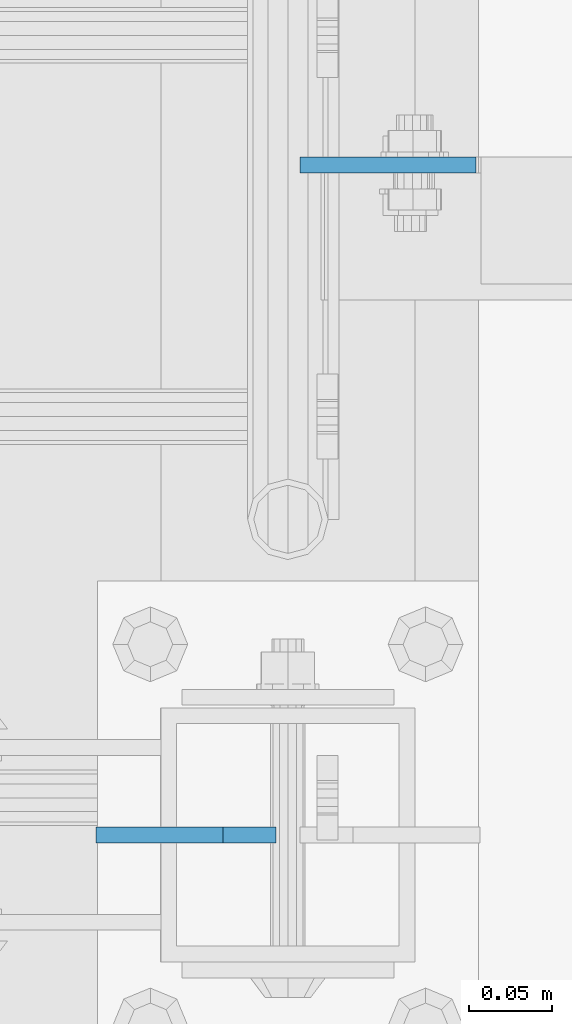
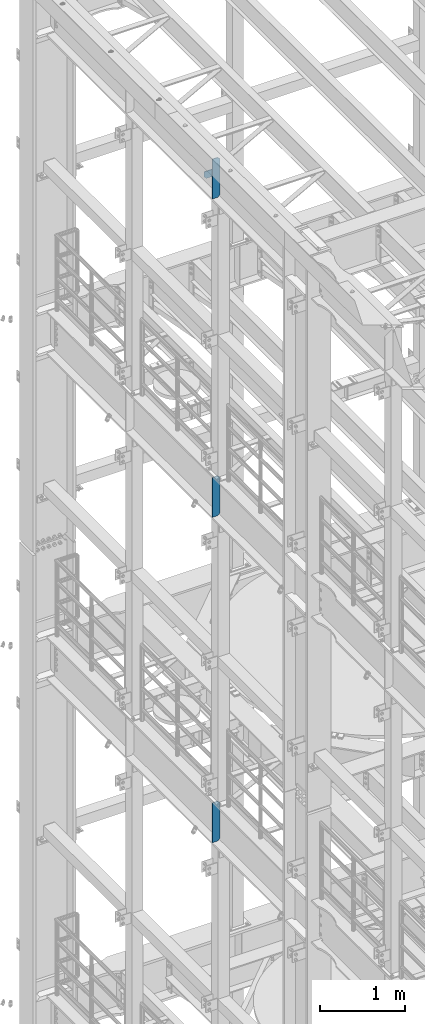
# One storey, part 1711 of 1876: 4 plates, 3 elements without a shape of their own.
"""IFC2X3 building model written with IfcOpenShell, lengths in millimetres."""

from ifc_helpers import new_model, si_unit, frame, origin_with_axes, place, context, subcontext, project, spatial, faceted_brep, material, type_object, element, aggregate, save


model = new_model("IFC2X3")

# Units and contexts
model_context = context("Model", 3, precision=1e-05, world=origin_with_axes())
body_context = subcontext(model_context, "Body", "Model", "MODEL_VIEW")
ifc_project = project(units=[si_unit("LENGTHUNIT", "METRE", prefix="MILLI"), si_unit("AREAUNIT", "SQUARE_METRE"), si_unit("VOLUMEUNIT", "CUBIC_METRE"), si_unit("MASSUNIT", "GRAM", prefix="KILO"), si_unit("TIMEUNIT", "SECOND"), si_unit("PLANEANGLEUNIT", "RADIAN"), si_unit("SOLIDANGLEUNIT", "STERADIAN"), si_unit("THERMODYNAMICTEMPERATUREUNIT", "DEGREE_CELSIUS"), si_unit("LUMINOUSINTENSITYUNIT", "LUMEN")], contexts=[model_context])

# Site, building, storey
site_placement = place(None, origin_with_axes())
site = spatial("IfcSite", under=ifc_project, at=site_placement, CompositionType="ELEMENT")
building_placement = place(site_placement, origin_with_axes())
building = spatial("IfcBuilding", under=site, at=building_placement, Name="Undefined", CompositionType="ELEMENT")
storey_placement = place(building_placement, origin_with_axes())
storey = spatial("IfcBuildingStorey", under=building, at=storey_placement, Name="Undefined", CompositionType="ELEMENT", Elevation=0.0)

# Assembly, plates
assembly_1_placement = place(storey_placement, origin_with_axes())
assembly_1 = element("IfcElementAssembly", 1, at=assembly_1_placement, inside=storey, Name="BEAM", AssemblyPlace="NOTDEFINED", PredefinedType="RIGID_FRAME")
ifc_material = material(Name="STEEL/A36")
plate_type_1 = type_object("IfcPlateType", PredefinedType="NOTDEFINED")
plate_1_placement = place(assembly_1_placement, frame((7.14374999999999, 10053.6375, 21958.3), z_axis=(0.0, 0.0, 1.0), x_axis=(1.0, 0.0, 0.0)))
plate_1 = element("IfcPlate", 2, at=plate_1_placement, type_object=plate_type_1, material=ifc_material, Name="PLATE", context=body_context, shape_type="Brep", body=[
    faceted_brep([(-9.76996261670138e-14, -4.76250000000073, 31.75), (-3.4106151360902e-06, -4.76249999999982, 104.420860290527), (-3.4106151360902e-06, 4.76249999999982, 104.420860290527), (-9.76996261670138e-14, 4.76250000000073, 31.75), (105.552177429199, -4.76249999999982, 104.420860290527), (105.552177429199, 4.76249999999982, 104.420860290527), (105.552177429199, -4.76249999999982, 0.0), (105.552177429199, 4.76249999999982, 0.0), (31.75, -4.76250000000073, 0.0), (31.75, 4.76250000000073, 0.0)], [[[0, 1, 2, 3]], [[1, 4, 5, 2]], [[4, 6, 7, 5]], [[6, 8, 9, 7]], [[8, 0, 3, 9]], [[5, 7, 9, 3, 2]], [[8, 6, 4, 1, 0]]]),
])
plate_type_2 = type_object("IfcPlateType", PredefinedType="NOTDEFINED")
plate_2_placement = place(assembly_1_placement, frame((-7.14374915193636, 9651.9999999841, 21958.3), z_axis=(0.0, 0.0, 1.0), x_axis=(-1.0, 0.0, 0.0)))
plate_2 = element("IfcPlate", 3, at=plate_2_placement, type_object=plate_type_2, material=ifc_material, Name="PLATE", context=body_context, shape_type="Brep", body=[
    faceted_brep([(-9.76996261670138e-14, -4.76250000000073, 31.75), (0.0, -4.76249999999982, 539.75), (0.0, 4.76249999999982, 539.75), (-9.76996261670138e-14, 4.76250000000073, 31.75), (31.75, -4.76249999999982, 571.5), (31.75, 4.76249999999982, 571.5), (107.949996948242, -4.76249999999982, 571.5), (107.949996948242, 4.76249999999982, 571.5), (107.950006484985, -4.76250000000073, 0.0), (107.950006484985, 4.76250000000073, 0.0), (31.75, -4.76250000000073, 0.0), (31.75, 4.76250000000073, 0.0)], [[[0, 1, 2, 3]], [[1, 4, 5, 2]], [[4, 6, 7, 5]], [[6, 8, 9, 7]], [[8, 10, 11, 9]], [[10, 0, 3, 11]], [[5, 7, 9, 11, 3, 2]], [[10, 8, 6, 4, 1, 0]]]),
])
aggregate(assembly_1, [plate_1, plate_2])

# Assembly, plate
assembly_2_placement = place(storey_placement, origin_with_axes())
assembly_2 = element("IfcElementAssembly", 4, at=assembly_2_placement, inside=storey, Name="BEAM", AssemblyPlace="NOTDEFINED", PredefinedType="RIGID_FRAME")
plate_3_placement = place(assembly_2_placement, frame((-7.14374915193636, 9651.9999999841, 17386.3), z_axis=(0.0, 0.0, 1.0), x_axis=(-1.0, 0.0, 0.0)))
plate_3 = element("IfcPlate", 5, at=plate_3_placement, type_object=plate_type_2, material=ifc_material, Name="PLATE", context=body_context, shape_type="Brep", body=[
    faceted_brep([(-9.76996261670138e-14, -4.76250000000073, 31.75), (0.0, -4.76249999999982, 539.75), (0.0, 4.76249999999982, 539.75), (-9.76996261670138e-14, 4.76250000000073, 31.75), (31.75, -4.76249999999982, 571.5), (31.75, 4.76249999999982, 571.5), (107.949996948242, -4.76249999999982, 571.5), (107.949996948242, 4.76249999999982, 571.5), (107.950006484985, -4.76250000000073, 0.0), (107.950006484985, 4.76250000000073, 0.0), (31.75, -4.76250000000073, 0.0), (31.75, 4.76250000000073, 0.0)], [[[0, 1, 2, 3]], [[1, 4, 5, 2]], [[4, 6, 7, 5]], [[6, 8, 9, 7]], [[8, 10, 11, 9]], [[10, 0, 3, 11]], [[5, 7, 9, 11, 3, 2]], [[10, 8, 6, 4, 1, 0]]]),
])
aggregate(assembly_2, [plate_3])

assembly_3_placement = place(storey_placement, origin_with_axes())
assembly_3 = element("IfcElementAssembly", 6, at=assembly_3_placement, inside=storey, Name="BEAM", AssemblyPlace="NOTDEFINED", PredefinedType="RIGID_FRAME")
plate_4_placement = place(assembly_3_placement, frame((-7.14374915193636, 9651.9999999841, 12712.7), z_axis=(0.0, 0.0, 1.0), x_axis=(-1.0, 0.0, 0.0)))
plate_4 = element("IfcPlate", 7, at=plate_4_placement, type_object=plate_type_2, material=ifc_material, Name="PLATE", context=body_context, shape_type="Brep", body=[
    faceted_brep([(-9.76996261670138e-14, -4.76250000000073, 31.75), (0.0, -4.76249999999982, 539.75), (0.0, 4.76249999999982, 539.75), (-9.76996261670138e-14, 4.76250000000073, 31.75), (31.75, -4.76249999999982, 571.5), (31.75, 4.76249999999982, 571.5), (107.949996948242, -4.76249999999982, 571.5), (107.949996948242, 4.76249999999982, 571.5), (107.950006484985, -4.76250000000073, 0.0), (107.950006484985, 4.76250000000073, 0.0), (31.75, -4.76250000000073, 0.0), (31.75, 4.76250000000073, 0.0)], [[[0, 1, 2, 3]], [[1, 4, 5, 2]], [[4, 6, 7, 5]], [[6, 8, 9, 7]], [[8, 10, 11, 9]], [[10, 0, 3, 11]], [[5, 7, 9, 11, 3, 2]], [[10, 8, 6, 4, 1, 0]]]),
])
aggregate(assembly_3, [plate_4])

save(model, "model.ifc")
